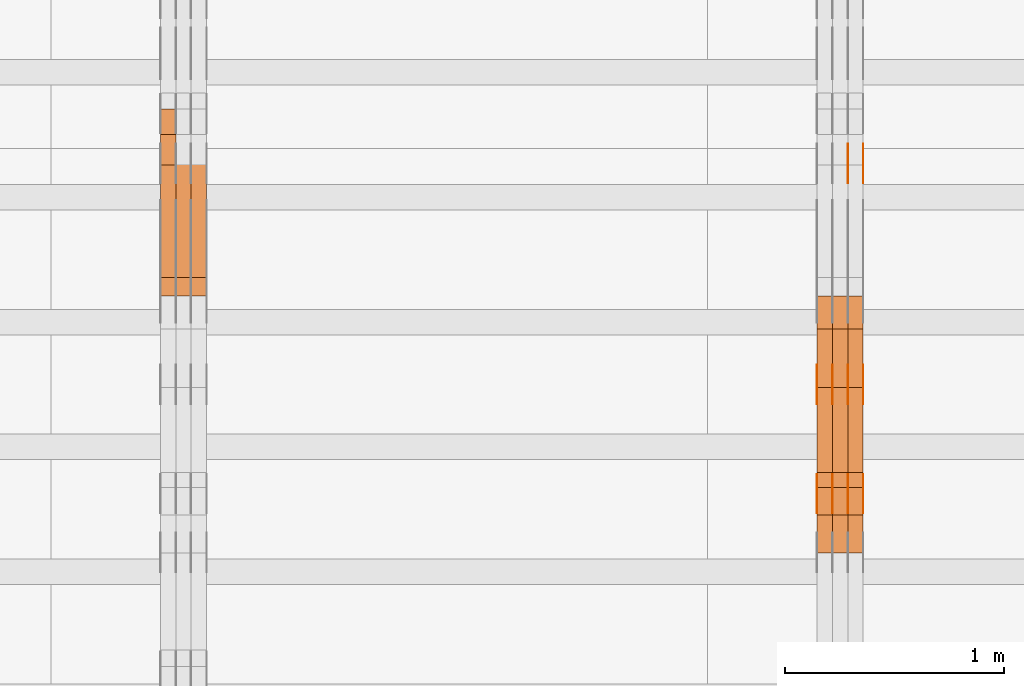
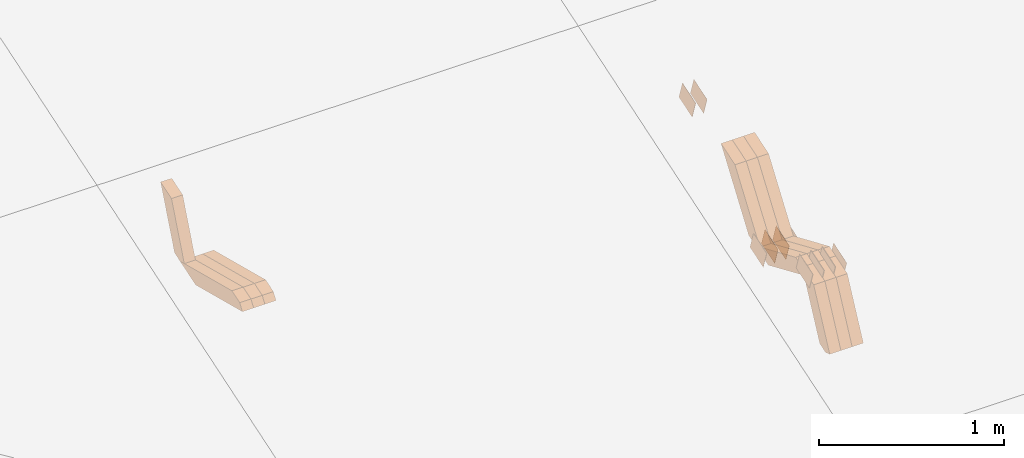
# One storey, part 258 of 385: 28 proxies.
"""IFC2X3 building model written with IfcOpenShell, lengths in millimetres."""

from ifc_helpers import new_model, entity, si_unit, converted_unit, derived_unit, direction, frame, origin, place, context, subcontext, project, spatial, polyline, outline, extrude, source, transform, mapped, material, type_object, type_shapes, element, save


model = new_model("IFC2X3")

# Units and contexts
model_context = context("Model", 3, precision=0.01, world=origin(), true_north=direction((6.12303176911189e-17, 1.0)))
body_context = subcontext(model_context, "Body", "Model", "MODEL_VIEW")
ifc_project = project(units=[si_unit("LENGTHUNIT", "METRE", prefix="MILLI"), si_unit("AREAUNIT", "SQUARE_METRE"), si_unit("VOLUMEUNIT", "CUBIC_METRE"), converted_unit("PLANEANGLEUNIT", "DEGREE", entity("IfcRatioMeasure", 0.0174532925199433), si_unit("PLANEANGLEUNIT", "RADIAN"), dimensions=[0, 0, 0, 0, 0, 0, 0]), si_unit("MASSUNIT", "GRAM", prefix="KILO"), derived_unit("MASSDENSITYUNIT", [(si_unit("MASSUNIT", "GRAM", prefix="KILO"), 1), (si_unit("LENGTHUNIT", "METRE"), -3)]), si_unit("TIMEUNIT", "SECOND"), si_unit("FREQUENCYUNIT", "HERTZ"), si_unit("THERMODYNAMICTEMPERATUREUNIT", "DEGREE_CELSIUS"), derived_unit("THERMALTRANSMITTANCEUNIT", [(si_unit("MASSUNIT", "GRAM", prefix="KILO"), 1), (si_unit("THERMODYNAMICTEMPERATUREUNIT", "KELVIN"), -1), (si_unit("TIMEUNIT", "SECOND"), -3)]), derived_unit("VOLUMETRICFLOWRATEUNIT", [(si_unit("LENGTHUNIT", "METRE"), 3), (si_unit("TIMEUNIT", "SECOND"), -1)]), si_unit("ELECTRICCURRENTUNIT", "AMPERE"), si_unit("ELECTRICVOLTAGEUNIT", "VOLT"), si_unit("POWERUNIT", "WATT"), si_unit("FORCEUNIT", "NEWTON", prefix="KILO"), si_unit("ILLUMINANCEUNIT", "LUX"), si_unit("LUMINOUSFLUXUNIT", "LUMEN"), si_unit("LUMINOUSINTENSITYUNIT", "CANDELA"), derived_unit("USERDEFINED", [(si_unit("MASSUNIT", "GRAM", prefix="KILO"), -1), (si_unit("LENGTHUNIT", "METRE"), -2), (si_unit("TIMEUNIT", "SECOND"), 3), (si_unit("LUMINOUSFLUXUNIT", "LUMEN"), 1)]), derived_unit("LINEARVELOCITYUNIT", [(si_unit("LENGTHUNIT", "METRE"), 1), (si_unit("TIMEUNIT", "SECOND"), -1)]), si_unit("PRESSUREUNIT", "PASCAL"), derived_unit("USERDEFINED", [(si_unit("LENGTHUNIT", "METRE"), -2), (si_unit("MASSUNIT", "GRAM", prefix="KILO"), 1), (si_unit("TIMEUNIT", "SECOND"), -2)])], contexts=[model_context])

# Site, building, storey
site_placement = place(None, origin())
site = spatial("IfcSite", under=ifc_project, at=site_placement, CompositionType="ELEMENT")
building_placement = place(site_placement, origin())
building = spatial("IfcBuilding", under=site, at=building_placement, CompositionType="ELEMENT")
storey_placement = place(building_placement, origin())
storey = spatial("IfcBuildingStorey", under=building, at=storey_placement, Name="Default", CompositionType="ELEMENT", Elevation=0.0)

# Proxies
ifc_material_1 = material(Name="IfcSurfaceStyle #488358")
building_element_proxy_type_1 = type_object("IfcBuildingElementProxyType", PredefinedType="NOTDEFINED", material=ifc_material_1)
shared_shape_1 = source(origin(), body_context, "Body", "SweptSolid", [
    extrude(outline(polyline([(-74.9998565677179, -60.000059685226), (74.9998794200128, -60.000059685226), (74.9998565677179, 60.000059685226), (-74.9998794200128, 60.000059685226), (-74.9998565677179, -60.000059685226)])), frame((75.0001976720505, 60.000059685226, 0.0), z_axis=(0.0, 0.0, 1.0), x_axis=(-1.0, 0.0, 0.0)), (0.0, 0.0, 1.0), 1.3),
])
type_shapes(building_element_proxy_type_1, [shared_shape_1])
proxy_1_placement = place(building_placement, frame((39386.3, 8537.53090236182, 1950.11166041942), z_axis=(-1.0, 0.0, 0.0), x_axis=(0.0, 0.951056516295124, 0.309016994375039)))
element("IfcBuildingElementProxy", 1, at=proxy_1_placement, inside=storey, type_object=building_element_proxy_type_1, material=ifc_material_1, context=body_context, shape_type="MappedRepresentation", body=[
    mapped(shared_shape_1, transform((0.0, 0.0, 0.0), scale=1.0)),
])
ifc_material_2 = material(Name="IfcSurfaceStyle #488301")
building_element_proxy_type_2 = type_object("IfcBuildingElementProxyType", PredefinedType="NOTDEFINED", material=ifc_material_2)
shared_shape_2 = source(origin(), body_context, "Body", "SweptSolid", [
    extrude(outline(polyline([(-74.9998565677179, -60.000059685226), (74.9998794200128, -60.000059685226), (74.9998565677179, 60.000059685226), (-74.9998794200128, 60.000059685226), (-74.9998565677179, -60.000059685226)])), frame((75.0001976720505, 60.000059685226, 0.0), z_axis=(0.0, 0.0, 1.0), x_axis=(-1.0, 0.0, 0.0)), (0.0, 0.0, 1.0), 1.3),
])
type_shapes(building_element_proxy_type_2, [shared_shape_2])
proxy_2_placement = place(building_placement, frame((39315.0, 8537.53090236182, 1950.11166041942), z_axis=(-1.0, 0.0, 0.0), x_axis=(0.0, 0.951056516295124, 0.309016994375039)))
element("IfcBuildingElementProxy", 2, at=proxy_2_placement, inside=storey, type_object=building_element_proxy_type_2, material=ifc_material_2, context=body_context, shape_type="MappedRepresentation", body=[
    mapped(shared_shape_2, transform((0.0, 0.0, 0.0), scale=1.0)),
])
ifc_material_3 = material(Name="IfcSurfaceStyle #488244")
building_element_proxy_type_3 = type_object("IfcBuildingElementProxyType", PredefinedType="NOTDEFINED", material=ifc_material_3)
shared_shape_3 = source(origin(), body_context, "Body", "SweptSolid", [
    extrude(outline(polyline([(-74.9998565677179, -60.000059685226), (74.9998794200128, -60.000059685226), (74.9998565677179, 60.000059685226), (-74.9998794200128, 60.000059685226), (-74.9998565677179, -60.000059685226)])), frame((75.0001976720505, 60.000059685226, 0.0), z_axis=(0.0, 0.0, 1.0), x_axis=(-1.0, 0.0, 0.0)), (0.0, 0.0, 1.0), 1.3),
])
type_shapes(building_element_proxy_type_3, [shared_shape_3])
proxy_3_placement = place(building_placement, frame((39316.3, 8537.53090236182, 1950.11166041942), z_axis=(-1.0, 0.0, 0.0), x_axis=(0.0, 0.951056516295124, 0.309016994375039)))
element("IfcBuildingElementProxy", 3, at=proxy_3_placement, inside=storey, type_object=building_element_proxy_type_3, material=ifc_material_3, context=body_context, shape_type="MappedRepresentation", body=[
    mapped(shared_shape_3, transform((0.0, 0.0, 0.0), scale=1.0)),
])
ifc_material_4 = material(Name="IfcSurfaceStyle #483228")
building_element_proxy_type_4 = type_object("IfcBuildingElementProxyType", PredefinedType="NOTDEFINED", material=ifc_material_4)
shared_shape_4 = source(origin(), body_context, "Body", "SweptSolid", [
    extrude(outline(polyline([(-74.9998565677169, -60.0000596852269), (74.9998794200137, -60.0000596852269), (74.9998565677151, 60.0000596852269), (-74.9998794200119, 60.0000596852269), (-74.9998565677169, -60.0000596852269)])), frame((74.9998794200137, 60.0000596852269, 0.0), z_axis=(0.0, 0.0, 1.0), x_axis=(-1.0, 0.0, 0.0)), (0.0, 0.0, 1.0), 1.3),
])
type_shapes(building_element_proxy_type_4, [shared_shape_4])
proxy_4_placement = place(building_placement, frame((39386.3, 7527.6269081625, 1621.97418552253), z_axis=(-1.0, 0.0, 0.0), x_axis=(0.0, 0.951056516295124, 0.309016994375039)))
element("IfcBuildingElementProxy", 4, at=proxy_4_placement, inside=storey, type_object=building_element_proxy_type_4, material=ifc_material_4, context=body_context, shape_type="MappedRepresentation", body=[
    mapped(shared_shape_4, transform((0.0, 0.0, 0.0), scale=1.0)),
])
ifc_material_5 = material(Name="IfcSurfaceStyle #483171")
building_element_proxy_type_5 = type_object("IfcBuildingElementProxyType", PredefinedType="NOTDEFINED", material=ifc_material_5)
shared_shape_5 = source(origin(), body_context, "Body", "SweptSolid", [
    extrude(outline(polyline([(-74.9998565677169, -60.0000596852269), (74.9998794200137, -60.0000596852269), (74.9998565677151, 60.0000596852269), (-74.9998794200119, 60.0000596852269), (-74.9998565677169, -60.0000596852269)])), frame((74.9998794200137, 60.0000596852269, 0.0), z_axis=(0.0, 0.0, 1.0), x_axis=(-1.0, 0.0, 0.0)), (0.0, 0.0, 1.0), 1.3),
])
type_shapes(building_element_proxy_type_5, [shared_shape_5])
proxy_5_placement = place(building_placement, frame((39315.0, 7527.6269081625, 1621.97418552253), z_axis=(-1.0, 0.0, 0.0), x_axis=(0.0, 0.951056516295124, 0.309016994375039)))
element("IfcBuildingElementProxy", 5, at=proxy_5_placement, inside=storey, type_object=building_element_proxy_type_5, material=ifc_material_5, context=body_context, shape_type="MappedRepresentation", body=[
    mapped(shared_shape_5, transform((0.0, 0.0, 0.0), scale=1.0)),
])
ifc_material_6 = material(Name="IfcSurfaceStyle #483114")
building_element_proxy_type_6 = type_object("IfcBuildingElementProxyType", PredefinedType="NOTDEFINED", material=ifc_material_6)
shared_shape_6 = source(origin(), body_context, "Body", "SweptSolid", [
    extrude(outline(polyline([(-74.9998565677169, -60.0000596852269), (74.9998794200137, -60.0000596852269), (74.9998565677151, 60.0000596852269), (-74.9998794200119, 60.0000596852269), (-74.9998565677169, -60.0000596852269)])), frame((74.9998794200137, 60.0000596852269, 0.0), z_axis=(0.0, 0.0, 1.0), x_axis=(-1.0, 0.0, 0.0)), (0.0, 0.0, 1.0), 1.3),
])
type_shapes(building_element_proxy_type_6, [shared_shape_6])
proxy_6_placement = place(building_placement, frame((39316.3, 7527.6269081625, 1621.97418552253), z_axis=(-1.0, 0.0, 0.0), x_axis=(0.0, 0.951056516295124, 0.309016994375039)))
element("IfcBuildingElementProxy", 6, at=proxy_6_placement, inside=storey, type_object=building_element_proxy_type_6, material=ifc_material_6, context=body_context, shape_type="MappedRepresentation", body=[
    mapped(shared_shape_6, transform((0.0, 0.0, 0.0), scale=1.0)),
])
ifc_material_7 = material(Name="IfcSurfaceStyle #483057")
building_element_proxy_type_7 = type_object("IfcBuildingElementProxyType", PredefinedType="NOTDEFINED", material=ifc_material_7)
shared_shape_7 = source(origin(), body_context, "Body", "SweptSolid", [
    extrude(outline(polyline([(-74.9998565677169, -60.0000596852269), (74.9998794200137, -60.0000596852269), (74.9998565677151, 60.0000596852269), (-74.9998794200119, 60.0000596852269), (-74.9998565677169, -60.0000596852269)])), frame((74.9998794200137, 60.0000596852269, 0.0), z_axis=(0.0, 0.0, 1.0), x_axis=(-1.0, 0.0, 0.0)), (0.0, 0.0, 1.0), 1.29999999999999),
])
type_shapes(building_element_proxy_type_7, [shared_shape_7])
proxy_7_placement = place(building_placement, frame((39245.0, 7527.6269081625, 1621.97418552253), z_axis=(-1.0, 0.0, 0.0), x_axis=(0.0, 0.951056516295124, 0.309016994375039)))
element("IfcBuildingElementProxy", 7, at=proxy_7_placement, inside=storey, type_object=building_element_proxy_type_7, material=ifc_material_7, context=body_context, shape_type="MappedRepresentation", body=[
    mapped(shared_shape_7, transform((0.0, 0.0, 0.0), scale=1.0)),
])
ifc_material_8 = material(Name="IfcSurfaceStyle #483000")
building_element_proxy_type_8 = type_object("IfcBuildingElementProxyType", PredefinedType="NOTDEFINED", material=ifc_material_8)
shared_shape_8 = source(origin(), body_context, "Body", "SweptSolid", [
    extrude(outline(polyline([(-74.9998565677169, -60.0000596852269), (74.9998794200137, -60.0000596852269), (74.9998565677151, 60.0000596852269), (-74.9998794200119, 60.0000596852269), (-74.9998565677169, -60.0000596852269)])), frame((74.9998794200137, 60.0000596852269, 0.0), z_axis=(0.0, 0.0, 1.0), x_axis=(-1.0, 0.0, 0.0)), (0.0, 0.0, 1.0), 1.29999999999999),
])
type_shapes(building_element_proxy_type_8, [shared_shape_8])
proxy_8_placement = place(building_placement, frame((39246.3, 7527.6269081625, 1621.97418552253), z_axis=(-1.0, 0.0, 0.0), x_axis=(0.0, 0.951056516295124, 0.309016994375039)))
element("IfcBuildingElementProxy", 8, at=proxy_8_placement, inside=storey, type_object=building_element_proxy_type_8, material=ifc_material_8, context=body_context, shape_type="MappedRepresentation", body=[
    mapped(shared_shape_8, transform((0.0, 0.0, 0.0), scale=1.0)),
])
ifc_material_9 = material(Name="IfcSurfaceStyle #482943")
building_element_proxy_type_9 = type_object("IfcBuildingElementProxyType", PredefinedType="NOTDEFINED", material=ifc_material_9)
shared_shape_9 = source(origin(), body_context, "Body", "SweptSolid", [
    extrude(outline(polyline([(-74.9998565677169, -60.0000596852269), (74.9998794200137, -60.0000596852269), (74.9998565677151, 60.0000596852269), (-74.9998794200119, 60.0000596852269), (-74.9998565677169, -60.0000596852269)])), frame((74.9998794200137, 60.0000596852269, 0.0), z_axis=(0.0, 0.0, 1.0), x_axis=(-1.0, 0.0, 0.0)), (0.0, 0.0, 1.0), 1.29999999999999),
])
type_shapes(building_element_proxy_type_9, [shared_shape_9])
proxy_9_placement = place(building_placement, frame((39175.0, 7527.6269081625, 1621.97418552253), z_axis=(-1.0, 0.0, 0.0), x_axis=(0.0, 0.951056516295124, 0.309016994375039)))
element("IfcBuildingElementProxy", 9, at=proxy_9_placement, inside=storey, type_object=building_element_proxy_type_9, material=ifc_material_9, context=body_context, shape_type="MappedRepresentation", body=[
    mapped(shared_shape_9, transform((0.0, 0.0, 0.0), scale=1.0)),
])
ifc_material_10 = material(Name="IfcSurfaceStyle #472968")
building_element_proxy_type_10 = type_object("IfcBuildingElementProxyType", PredefinedType="NOTDEFINED", material=ifc_material_10)
shared_shape_10 = source(origin(), body_context, "Body", "SweptSolid", [
    extrude(outline(polyline([(-74.9998565677233, -60.0000596852342), (74.9998794200074, -60.0000596852342), (74.9998565677233, 60.0000596852342), (-74.9998794200074, 60.0000596852342), (-74.9998565677233, -60.0000596852342)])), frame((74.9998794200073, 60.0000596852342, 0.0), z_axis=(0.0, 0.0, 1.0), x_axis=(-1.0, 0.0, 0.0)), (0.0, 0.0, 1.0), 1.3),
])
type_shapes(building_element_proxy_type_10, [shared_shape_10])
proxy_10_placement = place(building_placement, frame((39386.3, 7029.15620503751, 1786.70025974129), z_axis=(-1.0, 0.0, 0.0), x_axis=(0.0, 0.951056516295154, 0.309016994374948)))
element("IfcBuildingElementProxy", 10, at=proxy_10_placement, inside=storey, type_object=building_element_proxy_type_10, material=ifc_material_10, context=body_context, shape_type="MappedRepresentation", body=[
    mapped(shared_shape_10, transform((0.0, 0.0, 0.0), scale=1.0)),
])
ifc_material_11 = material(Name="IfcSurfaceStyle #472911")
building_element_proxy_type_11 = type_object("IfcBuildingElementProxyType", PredefinedType="NOTDEFINED", material=ifc_material_11)
shared_shape_11 = source(origin(), body_context, "Body", "SweptSolid", [
    extrude(outline(polyline([(-74.9998565677233, -60.0000596852342), (74.9998794200074, -60.0000596852342), (74.9998565677233, 60.0000596852342), (-74.9998794200074, 60.0000596852342), (-74.9998565677233, -60.0000596852342)])), frame((74.9998794200073, 60.0000596852342, 0.0), z_axis=(0.0, 0.0, 1.0), x_axis=(-1.0, 0.0, 0.0)), (0.0, 0.0, 1.0), 1.3),
])
type_shapes(building_element_proxy_type_11, [shared_shape_11])
proxy_11_placement = place(building_placement, frame((39315.0, 7029.15620503751, 1786.70025974129), z_axis=(-1.0, 0.0, 0.0), x_axis=(0.0, 0.951056516295154, 0.309016994374948)))
element("IfcBuildingElementProxy", 11, at=proxy_11_placement, inside=storey, type_object=building_element_proxy_type_11, material=ifc_material_11, context=body_context, shape_type="MappedRepresentation", body=[
    mapped(shared_shape_11, transform((0.0, 0.0, 0.0), scale=1.0)),
])
ifc_material_12 = material(Name="IfcSurfaceStyle #472854")
building_element_proxy_type_12 = type_object("IfcBuildingElementProxyType", PredefinedType="NOTDEFINED", material=ifc_material_12)
shared_shape_12 = source(origin(), body_context, "Body", "SweptSolid", [
    extrude(outline(polyline([(-74.9998565677233, -60.0000596852342), (74.9998794200074, -60.0000596852342), (74.9998565677233, 60.0000596852342), (-74.9998794200074, 60.0000596852342), (-74.9998565677233, -60.0000596852342)])), frame((74.9998794200073, 60.0000596852342, 0.0), z_axis=(0.0, 0.0, 1.0), x_axis=(-1.0, 0.0, 0.0)), (0.0, 0.0, 1.0), 1.3),
])
type_shapes(building_element_proxy_type_12, [shared_shape_12])
proxy_12_placement = place(building_placement, frame((39316.3, 7029.15620503751, 1786.70025974129), z_axis=(-1.0, 0.0, 0.0), x_axis=(0.0, 0.951056516295154, 0.309016994374948)))
element("IfcBuildingElementProxy", 12, at=proxy_12_placement, inside=storey, type_object=building_element_proxy_type_12, material=ifc_material_12, context=body_context, shape_type="MappedRepresentation", body=[
    mapped(shared_shape_12, transform((0.0, 0.0, 0.0), scale=1.0)),
])
ifc_material_13 = material(Name="IfcSurfaceStyle #472797")
building_element_proxy_type_13 = type_object("IfcBuildingElementProxyType", PredefinedType="NOTDEFINED", material=ifc_material_13)
shared_shape_13 = source(origin(), body_context, "Body", "SweptSolid", [
    extrude(outline(polyline([(-74.9998565677233, -60.0000596852342), (74.9998794200074, -60.0000596852342), (74.9998565677233, 60.0000596852342), (-74.9998794200074, 60.0000596852342), (-74.9998565677233, -60.0000596852342)])), frame((74.9998794200073, 60.0000596852342, 0.0), z_axis=(0.0, 0.0, 1.0), x_axis=(-1.0, 0.0, 0.0)), (0.0, 0.0, 1.0), 1.29999999999999),
])
type_shapes(building_element_proxy_type_13, [shared_shape_13])
proxy_13_placement = place(building_placement, frame((39245.0, 7029.15620503751, 1786.70025974129), z_axis=(-1.0, 0.0, 0.0), x_axis=(0.0, 0.951056516295154, 0.309016994374948)))
element("IfcBuildingElementProxy", 13, at=proxy_13_placement, inside=storey, type_object=building_element_proxy_type_13, material=ifc_material_13, context=body_context, shape_type="MappedRepresentation", body=[
    mapped(shared_shape_13, transform((0.0, 0.0, 0.0), scale=1.0)),
])
ifc_material_14 = material(Name="IfcSurfaceStyle #472740")
building_element_proxy_type_14 = type_object("IfcBuildingElementProxyType", PredefinedType="NOTDEFINED", material=ifc_material_14)
shared_shape_14 = source(origin(), body_context, "Body", "SweptSolid", [
    extrude(outline(polyline([(-74.9998565677233, -60.0000596852342), (74.9998794200074, -60.0000596852342), (74.9998565677233, 60.0000596852342), (-74.9998794200074, 60.0000596852342), (-74.9998565677233, -60.0000596852342)])), frame((74.9998794200073, 60.0000596852342, 0.0), z_axis=(0.0, 0.0, 1.0), x_axis=(-1.0, 0.0, 0.0)), (0.0, 0.0, 1.0), 1.29999999999999),
])
type_shapes(building_element_proxy_type_14, [shared_shape_14])
proxy_14_placement = place(building_placement, frame((39246.3, 7029.15620503751, 1786.70025974129), z_axis=(-1.0, 0.0, 0.0), x_axis=(0.0, 0.951056516295154, 0.309016994374948)))
element("IfcBuildingElementProxy", 14, at=proxy_14_placement, inside=storey, type_object=building_element_proxy_type_14, material=ifc_material_14, context=body_context, shape_type="MappedRepresentation", body=[
    mapped(shared_shape_14, transform((0.0, 0.0, 0.0), scale=1.0)),
])
ifc_material_15 = material(Name="IfcSurfaceStyle #472683")
building_element_proxy_type_15 = type_object("IfcBuildingElementProxyType", PredefinedType="NOTDEFINED", material=ifc_material_15)
shared_shape_15 = source(origin(), body_context, "Body", "SweptSolid", [
    extrude(outline(polyline([(-74.9998565677233, -60.0000596852342), (74.9998794200074, -60.0000596852342), (74.9998565677233, 60.0000596852342), (-74.9998794200074, 60.0000596852342), (-74.9998565677233, -60.0000596852342)])), frame((74.9998794200073, 60.0000596852342, 0.0), z_axis=(0.0, 0.0, 1.0), x_axis=(-1.0, 0.0, 0.0)), (0.0, 0.0, 1.0), 1.29999999999999),
])
type_shapes(building_element_proxy_type_15, [shared_shape_15])
proxy_15_placement = place(building_placement, frame((39175.0, 7029.15620503751, 1786.70025974129), z_axis=(-1.0, 0.0, 0.0), x_axis=(0.0, 0.951056516295154, 0.309016994374948)))
element("IfcBuildingElementProxy", 15, at=proxy_15_placement, inside=storey, type_object=building_element_proxy_type_15, material=ifc_material_15, context=body_context, shape_type="MappedRepresentation", body=[
    mapped(shared_shape_15, transform((0.0, 0.0, 0.0), scale=1.0)),
])
ifc_material_16 = material(Name="IfcSurfaceStyle #460476")
building_element_proxy_type_16 = type_object("IfcBuildingElementProxyType", Name="T1-W17 460474", PredefinedType="NOTDEFINED", material=ifc_material_16)
shared_shape_16 = source(origin(), body_context, "Body", "SweptSolid", [
    extrude(outline(polyline([(-364.271754334175, -47.5002955168173), (154.762247185537, -47.5002955168173), (218.32500198375, 4.1746158945366e-05), (228.330650189718, 47.5002746437378), (-237.14614502483, 47.5002746437378), (-364.271754334175, -47.5002955168173)])), frame((228.330650189718, 47.5002746437378, 0.0), z_axis=(0.0, 0.0, 1.0), x_axis=(-1.0, 0.0, 0.0)), (0.0, 0.0, 1.0), 70.0),
])
type_shapes(building_element_proxy_type_16, [shared_shape_16])
proxy_16_placement = place(building_placement, frame((39385.0, 7603.591796875, 1617.27880859375), z_axis=(-1.0, 0.0, 0.0), x_axis=(0.0, 0.576852646364743, 0.816848226038346)))
element("IfcBuildingElementProxy", 16, at=proxy_16_placement, inside=storey, type_object=building_element_proxy_type_16, material=ifc_material_16, Name="T1-W17", context=body_context, shape_type="MappedRepresentation", body=[
    mapped(shared_shape_16, transform((0.0, 0.0, 0.0), scale=1.0)),
])
ifc_material_17 = material(Name="IfcSurfaceStyle #460410")
building_element_proxy_type_17 = type_object("IfcBuildingElementProxyType", Name="T1-W17 460408", PredefinedType="NOTDEFINED", material=ifc_material_17)
shared_shape_17 = source(origin(), body_context, "Body", "SweptSolid", [
    extrude(outline(polyline([(-364.271754334175, -47.5002955168173), (154.762247185537, -47.5002955168173), (218.32500198375, 4.1746158945366e-05), (228.330650189718, 47.5002746437378), (-237.14614502483, 47.5002746437378), (-364.271754334175, -47.5002955168173)])), frame((228.330650189718, 47.5002746437378, 0.0), z_axis=(0.0, 0.0, 1.0), x_axis=(-1.0, 0.0, 0.0)), (0.0, 0.0, 1.0), 70.0),
])
type_shapes(building_element_proxy_type_17, [shared_shape_17])
proxy_17_placement = place(building_placement, frame((39315.0, 7603.591796875, 1617.27880859375), z_axis=(-1.0, 0.0, 0.0), x_axis=(0.0, 0.576852646364743, 0.816848226038346)))
element("IfcBuildingElementProxy", 17, at=proxy_17_placement, inside=storey, type_object=building_element_proxy_type_17, material=ifc_material_17, Name="T1-W17", context=body_context, shape_type="MappedRepresentation", body=[
    mapped(shared_shape_17, transform((0.0, 0.0, 0.0), scale=1.0)),
])
ifc_material_18 = material(Name="IfcSurfaceStyle #460344")
building_element_proxy_type_18 = type_object("IfcBuildingElementProxyType", Name="T1-W17 460342", PredefinedType="NOTDEFINED", material=ifc_material_18)
shared_shape_18 = source(origin(), body_context, "Body", "SweptSolid", [
    extrude(outline(polyline([(-364.271754334175, -47.5002955168173), (154.762247185537, -47.5002955168173), (218.32500198375, 4.1746158945366e-05), (228.330650189718, 47.5002746437378), (-237.14614502483, 47.5002746437378), (-364.271754334175, -47.5002955168173)])), frame((228.330650189718, 47.5002746437378, 0.0), z_axis=(0.0, 0.0, 1.0), x_axis=(-1.0, 0.0, 0.0)), (0.0, 0.0, 1.0), 70.0),
])
type_shapes(building_element_proxy_type_18, [shared_shape_18])
proxy_18_placement = place(building_placement, frame((39245.0, 7603.591796875, 1617.27880859375), z_axis=(-1.0, 0.0, 0.0), x_axis=(0.0, 0.576852646364743, 0.816848226038346)))
element("IfcBuildingElementProxy", 18, at=proxy_18_placement, inside=storey, type_object=building_element_proxy_type_18, material=ifc_material_18, Name="T1-W17", context=body_context, shape_type="MappedRepresentation", body=[
    mapped(shared_shape_18, transform((0.0, 0.0, 0.0), scale=1.0)),
])
ifc_material_19 = material(Name="IfcSurfaceStyle #460080")
building_element_proxy_type_19 = type_object("IfcBuildingElementProxyType", Name="T1-W28 460078", PredefinedType="NOTDEFINED", material=ifc_material_19)
shared_shape_19 = source(origin(), body_context, "Body", "SweptSolid", [
    extrude(outline(polyline([(-217.926999432742, -47.5002417204892), (200.85556309928, -47.5002417204892), (198.503183549447, 8.27993157516647e-05), (144.500539771884, 47.5002003208314), (-325.932286987868, 47.5002003208314), (-217.926999432742, -47.5002417204892)])), frame((200.855855188284, 47.5002003208314, 0.0), z_axis=(0.0, 0.0, 1.0), x_axis=(-1.0, 0.0, 0.0)), (0.0, 0.0, 1.0), 70.0),
])
type_shapes(building_element_proxy_type_19, [shared_shape_19])
proxy_19_placement = place(building_placement, frame((39385.0, 7164.46308589723, 1806.71154838415), z_axis=(-1.0, 0.0, 0.0), x_axis=(0.0, 0.918207947119617, -0.396098681954861)))
element("IfcBuildingElementProxy", 19, at=proxy_19_placement, inside=storey, type_object=building_element_proxy_type_19, material=ifc_material_19, Name="T1-W28", context=body_context, shape_type="MappedRepresentation", body=[
    mapped(shared_shape_19, transform((0.0, 0.0, 0.0), scale=1.0)),
])
ifc_material_20 = material(Name="IfcSurfaceStyle #460014")
building_element_proxy_type_20 = type_object("IfcBuildingElementProxyType", Name="T1-W28 460012", PredefinedType="NOTDEFINED", material=ifc_material_20)
shared_shape_20 = source(origin(), body_context, "Body", "SweptSolid", [
    extrude(outline(polyline([(-217.926999432742, -47.5002417204892), (200.85556309928, -47.5002417204892), (198.503183549447, 8.27993157516647e-05), (144.500539771884, 47.5002003208314), (-325.932286987868, 47.5002003208314), (-217.926999432742, -47.5002417204892)])), frame((200.855855188284, 47.5002003208314, 0.0), z_axis=(0.0, 0.0, 1.0), x_axis=(-1.0, 0.0, 0.0)), (0.0, 0.0, 1.0), 70.0),
])
type_shapes(building_element_proxy_type_20, [shared_shape_20])
proxy_20_placement = place(building_placement, frame((39315.0, 7164.46308589723, 1806.71154838415), z_axis=(-1.0, 0.0, 0.0), x_axis=(0.0, 0.918207947119617, -0.396098681954861)))
element("IfcBuildingElementProxy", 20, at=proxy_20_placement, inside=storey, type_object=building_element_proxy_type_20, material=ifc_material_20, Name="T1-W28", context=body_context, shape_type="MappedRepresentation", body=[
    mapped(shared_shape_20, transform((0.0, 0.0, 0.0), scale=1.0)),
])
ifc_material_21 = material(Name="IfcSurfaceStyle #459948")
building_element_proxy_type_21 = type_object("IfcBuildingElementProxyType", Name="T1-W28 459946", PredefinedType="NOTDEFINED", material=ifc_material_21)
shared_shape_21 = source(origin(), body_context, "Body", "SweptSolid", [
    extrude(outline(polyline([(-217.926999432742, -47.5002417204892), (200.85556309928, -47.5002417204892), (198.503183549447, 8.27993157516647e-05), (144.500539771884, 47.5002003208314), (-325.932286987868, 47.5002003208314), (-217.926999432742, -47.5002417204892)])), frame((200.855855188284, 47.5002003208314, 0.0), z_axis=(0.0, 0.0, 1.0), x_axis=(-1.0, 0.0, 0.0)), (0.0, 0.0, 1.0), 70.0),
])
type_shapes(building_element_proxy_type_21, [shared_shape_21])
proxy_21_placement = place(building_placement, frame((39245.0, 7164.46308589723, 1806.71154838415), z_axis=(-1.0, 0.0, 0.0), x_axis=(0.0, 0.918207947119617, -0.396098681954861)))
element("IfcBuildingElementProxy", 21, at=proxy_21_placement, inside=storey, type_object=building_element_proxy_type_21, material=ifc_material_21, Name="T1-W28", context=body_context, shape_type="MappedRepresentation", body=[
    mapped(shared_shape_21, transform((0.0, 0.0, 0.0), scale=1.0)),
])
ifc_material_22 = material(Name="IfcSurfaceStyle #459684")
building_element_proxy_type_22 = type_object("IfcBuildingElementProxyType", Name="T1-W38 459682", PredefinedType="NOTDEFINED", material=ifc_material_22)
shared_shape_22 = source(origin(), body_context, "Body", "SweptSolid", [
    extrude(outline(polyline([(-298.027186733919, -47.5000251939178), (135.138415004037, -47.5000251939178), (181.282052802132, 0.000918984287993996), (187.347601017465, 47.4995657017738), (-205.740882089715, 47.4995657017739), (-298.027186733919, -47.5000251939178)])), frame((187.347846776827, 47.5001085012031, 0.0), z_axis=(0.0, 0.0, 1.0), x_axis=(-1.0, 0.0, 0.0)), (0.0, 0.0, 1.0), 70.0),
])
type_shapes(building_element_proxy_type_22, [shared_shape_22])
proxy_22_placement = place(building_placement, frame((39385.0, 6848.47987320449, 1368.44362234215), z_axis=(-1.0, 0.0, 0.0), x_axis=(0.0, 0.441034274474743, 0.897490261082836)))
element("IfcBuildingElementProxy", 22, at=proxy_22_placement, inside=storey, type_object=building_element_proxy_type_22, material=ifc_material_22, Name="T1-W38", context=body_context, shape_type="MappedRepresentation", body=[
    mapped(shared_shape_22, transform((0.0, 0.0, 0.0), scale=1.0)),
])
ifc_material_23 = material(Name="IfcSurfaceStyle #459618")
building_element_proxy_type_23 = type_object("IfcBuildingElementProxyType", Name="T1-W38 459616", PredefinedType="NOTDEFINED", material=ifc_material_23)
shared_shape_23 = source(origin(), body_context, "Body", "SweptSolid", [
    extrude(outline(polyline([(-298.027186733919, -47.5000251939178), (135.138415004037, -47.5000251939178), (181.282052802132, 0.000918984287993996), (187.347601017465, 47.4995657017738), (-205.740882089715, 47.4995657017739), (-298.027186733919, -47.5000251939178)])), frame((187.347846776827, 47.5001085012031, 0.0), z_axis=(0.0, 0.0, 1.0), x_axis=(-1.0, 0.0, 0.0)), (0.0, 0.0, 1.0), 70.0),
])
type_shapes(building_element_proxy_type_23, [shared_shape_23])
proxy_23_placement = place(building_placement, frame((39315.0, 6848.47987320449, 1368.44362234215), z_axis=(-1.0, 0.0, 0.0), x_axis=(0.0, 0.441034274474743, 0.897490261082836)))
element("IfcBuildingElementProxy", 23, at=proxy_23_placement, inside=storey, type_object=building_element_proxy_type_23, material=ifc_material_23, Name="T1-W38", context=body_context, shape_type="MappedRepresentation", body=[
    mapped(shared_shape_23, transform((0.0, 0.0, 0.0), scale=1.0)),
])
ifc_material_24 = material(Name="IfcSurfaceStyle #459552")
building_element_proxy_type_24 = type_object("IfcBuildingElementProxyType", Name="T1-W38 459550", PredefinedType="NOTDEFINED", material=ifc_material_24)
shared_shape_24 = source(origin(), body_context, "Body", "SweptSolid", [
    extrude(outline(polyline([(-298.027186733919, -47.5000251939178), (135.138415004037, -47.5000251939178), (181.282052802132, 0.000918984287993996), (187.347601017465, 47.4995657017738), (-205.740882089715, 47.4995657017739), (-298.027186733919, -47.5000251939178)])), frame((187.347846776827, 47.5001085012031, 0.0), z_axis=(0.0, 0.0, 1.0), x_axis=(-1.0, 0.0, 0.0)), (0.0, 0.0, 1.0), 70.0),
])
type_shapes(building_element_proxy_type_24, [shared_shape_24])
proxy_24_placement = place(building_placement, frame((39245.0, 6848.47987320449, 1368.44362234215), z_axis=(-1.0, 0.0, 0.0), x_axis=(0.0, 0.441034274474743, 0.897490261082836)))
element("IfcBuildingElementProxy", 24, at=proxy_24_placement, inside=storey, type_object=building_element_proxy_type_24, material=ifc_material_24, Name="T1-W38", context=body_context, shape_type="MappedRepresentation", body=[
    mapped(shared_shape_24, transform((0.0, 0.0, 0.0), scale=1.0)),
])
ifc_material_25 = material(Name="IfcSurfaceStyle #426704")
building_element_proxy_type_25 = type_object("IfcBuildingElementProxyType", Name="T1-W45 426702", PredefinedType="NOTDEFINED", material=ifc_material_25)
shared_shape_25 = source(origin(), body_context, "Body", "SweptSolid", [
    extrude(outline(polyline([(-275.953018340717, -47.500197738425), (128.971267956636, -47.5001977384251), (168.669977842085, -0.000132525443043008), (174.867371111815, 47.5002640011466), (-196.55559856982, 47.5002640011466), (-275.953018340717, -47.500197738425)])), frame((174.867371111815, 47.5002640011466, 0.0), z_axis=(0.0, 0.0, 1.0), x_axis=(-1.0, 0.0, 0.0)), (0.0, 0.0, 1.0), 70.0),
])
type_shapes(building_element_proxy_type_25, [shared_shape_25])
proxy_25_placement = place(building_placement, frame((36245.0, 8621.494140625, 1941.33422851563), z_axis=(-1.0, 0.0, 0.0), x_axis=(0.0, 0.372787901688292, 0.927916580493549)))
element("IfcBuildingElementProxy", 25, at=proxy_25_placement, inside=storey, type_object=building_element_proxy_type_25, material=ifc_material_25, Name="T1-W45", context=body_context, shape_type="MappedRepresentation", body=[
    mapped(shared_shape_25, transform((0.0, 0.0, 0.0), scale=1.0)),
])
ifc_material_26 = material(Name="IfcSurfaceStyle #426440")
building_element_proxy_type_26 = type_object("IfcBuildingElementProxyType", Name="T1-W11 426438", PredefinedType="NOTDEFINED", material=ifc_material_26)
shared_shape_26 = source(origin(), body_context, "Body", "SweptSolid", [
    extrude(outline(polyline([(-261.366417792209, -47.5000378467523), (260.949520182121, -47.5000378467523), (242.928845159301, -7.41559889341215e-06), (168.237407166939, 47.5000415545517), (-410.749354716152, 47.5000415545517), (-261.366417792209, -47.5000378467523)])), frame((260.949520182121, 47.5000415545517, 0.0), z_axis=(0.0, 0.0, 1.0), x_axis=(-1.0, 0.0, 0.0)), (0.0, 0.0, 1.0), 70.0),
])
type_shapes(building_element_proxy_type_26, [shared_shape_26])
proxy_26_placement = place(building_placement, frame((36385.0, 8017.44318793234, 2097.03832883996), z_axis=(-1.0, 0.0, 0.0), x_axis=(0.0, 0.968347201599873, -0.249607085543851)))
element("IfcBuildingElementProxy", 26, at=proxy_26_placement, inside=storey, type_object=building_element_proxy_type_26, material=ifc_material_26, Name="T1-W11", context=body_context, shape_type="MappedRepresentation", body=[
    mapped(shared_shape_26, transform((0.0, 0.0, 0.0), scale=1.0)),
])
ifc_material_27 = material(Name="IfcSurfaceStyle #426374")
building_element_proxy_type_27 = type_object("IfcBuildingElementProxyType", Name="T1-W11 426372", PredefinedType="NOTDEFINED", material=ifc_material_27)
shared_shape_27 = source(origin(), body_context, "Body", "SweptSolid", [
    extrude(outline(polyline([(-261.366417792209, -47.5000378467523), (260.949520182121, -47.5000378467523), (242.928845159301, -7.41559889341215e-06), (168.237407166939, 47.5000415545517), (-410.749354716152, 47.5000415545517), (-261.366417792209, -47.5000378467523)])), frame((260.949520182121, 47.5000415545517, 0.0), z_axis=(0.0, 0.0, 1.0), x_axis=(-1.0, 0.0, 0.0)), (0.0, 0.0, 1.0), 70.0),
])
type_shapes(building_element_proxy_type_27, [shared_shape_27])
proxy_27_placement = place(building_placement, frame((36315.0, 8017.44318793234, 2097.03832883996), z_axis=(-1.0, 0.0, 0.0), x_axis=(0.0, 0.968347201599873, -0.249607085543851)))
element("IfcBuildingElementProxy", 27, at=proxy_27_placement, inside=storey, type_object=building_element_proxy_type_27, material=ifc_material_27, Name="T1-W11", context=body_context, shape_type="MappedRepresentation", body=[
    mapped(shared_shape_27, transform((0.0, 0.0, 0.0), scale=1.0)),
])
ifc_material_28 = material(Name="IfcSurfaceStyle #426308")
building_element_proxy_type_28 = type_object("IfcBuildingElementProxyType", Name="T1-W11 426306", PredefinedType="NOTDEFINED", material=ifc_material_28)
shared_shape_28 = source(origin(), body_context, "Body", "SweptSolid", [
    extrude(outline(polyline([(-261.366417792209, -47.5000378467523), (260.949520182121, -47.5000378467523), (242.928845159301, -7.41559889341215e-06), (168.237407166939, 47.5000415545517), (-410.749354716152, 47.5000415545517), (-261.366417792209, -47.5000378467523)])), frame((260.949520182121, 47.5000415545517, 0.0), z_axis=(0.0, 0.0, 1.0), x_axis=(-1.0, 0.0, 0.0)), (0.0, 0.0, 1.0), 70.0),
])
type_shapes(building_element_proxy_type_28, [shared_shape_28])
proxy_28_placement = place(building_placement, frame((36245.0, 8017.44318793234, 2097.03832883996), z_axis=(-1.0, 0.0, 0.0), x_axis=(0.0, 0.968347201599873, -0.249607085543851)))
element("IfcBuildingElementProxy", 28, at=proxy_28_placement, inside=storey, type_object=building_element_proxy_type_28, material=ifc_material_28, Name="T1-W11", context=body_context, shape_type="MappedRepresentation", body=[
    mapped(shared_shape_28, transform((0.0, 0.0, 0.0), scale=1.0)),
])

save(model, "model.ifc")
